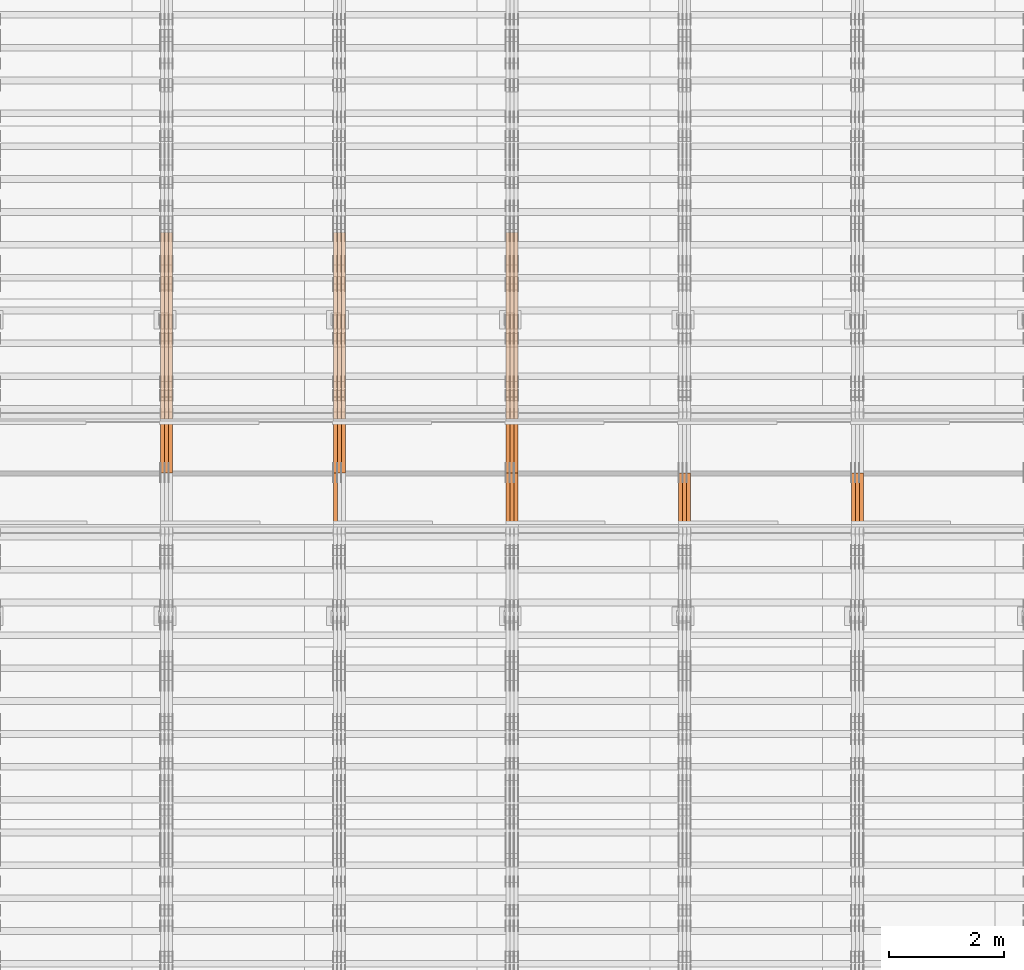
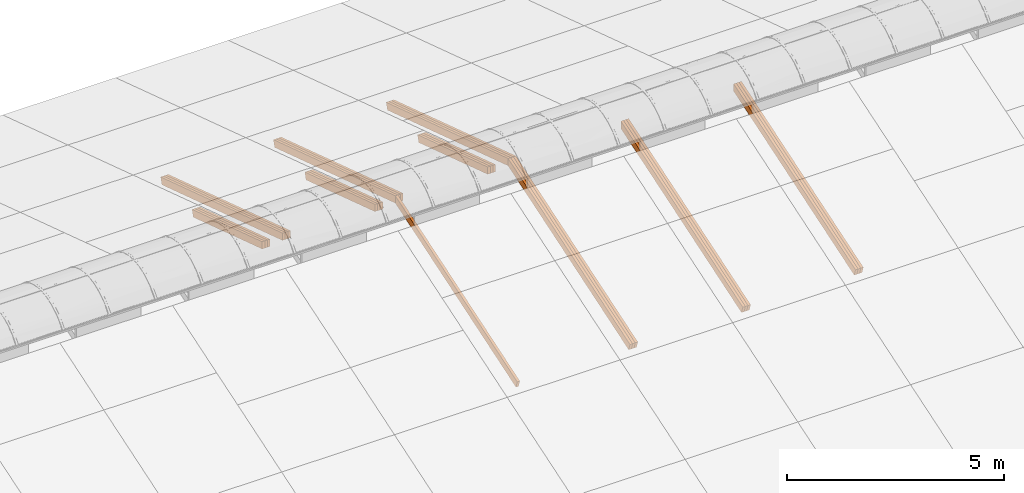
# One storey, part 18 of 385: 28 proxies.
"""IFC2X3 building model written with IfcOpenShell, lengths in millimetres."""

import ifcopenshell
import ifcopenshell.guid

model = None  # the IFC model being written
_history = None  # IfcOwnerHistory: only IFC2X3 demands one
_inside = {}  # id of a spatial element -> (the spatial element, [elements in it])
_under = {}  # id of a project, library or spatial element -> (it, [spatial elements below it])
_declared = {}  # id of a project -> (the project, [libraries it declares])
_typed = {}  # id of a type object -> (the type object, [elements of that type])
_made_of = {}  # id of a material, layer set ... -> (it, [elements and type objects made of it])


def new_model(schema):
    """Start an empty IFC model of exactly this schema.

    Asked for "IFC4X3", IfcOpenShell would pick the latest addendum, in which some entities
    have other attributes; the version numbers below select the first issue.
    IFC2X3 requires an IfcOwnerHistory on every rooted entity: one is made here for all.
    """
    global model, _history
    if schema == "IFC4X3":
        model = ifcopenshell.file(schema_version=(4, 3, 0, 0))
    else:
        model = ifcopenshell.file(schema=schema)
    _inside.clear()
    _under.clear()
    _declared.clear()
    _typed.clear()
    _made_of.clear()
    _history = None
    if model.schema == "IFC2X3":
        org = make("IfcOrganization", Name="unknown")
        user = make(
            "IfcPersonAndOrganization",
            ThePerson=make("IfcPerson", FamilyName="unknown"),
            TheOrganization=org,
        )
        app = make(
            "IfcApplication",
            ApplicationDeveloper=org,
            Version="unknown",
            ApplicationFullName="unknown",
            ApplicationIdentifier="unknown",
        )
        _history = make(
            "IfcOwnerHistory",
            OwningUser=user,
            OwningApplication=app,
            ChangeAction="ADDED",
            CreationDate=0,
        )
    return model


def make(cls, **values):
    """One entity of the class cls with the attributes given. An attribute that is None is left unset."""
    return model.create_entity(
        cls, **{name: value for name, value in values.items() if value is not None}
    )


def entity(cls, *values):
    """Any entity or typed value of the class cls, its attributes in the order of the schema. None: left unset."""
    e = model.create_entity(cls)
    for i, value in enumerate(values):
        if value is not None:
            e[i] = value
    return e


def rooted(cls, **values):
    """An entity with a GlobalId (a new one), such as an element, a storey or a relation."""
    return make(cls, GlobalId=ifcopenshell.guid.new(), OwnerHistory=_history, **values)


def si_unit(unit_type, name, prefix=None):
    """IfcSIUnit, for example si_unit("LENGTHUNIT", "METRE", prefix="MILLI")."""
    return make("IfcSIUnit", UnitType=unit_type, Prefix=prefix, Name=name)


def converted_unit(unit_type, name, factor, base, dimensions=None, offset=None):
    """IfcConversionBasedUnit, such as the inch: factor (a typed value) times the base unit."""
    return make(
        "IfcConversionBasedUnit"
        if offset is None
        else "IfcConversionBasedUnitWithOffset",
        ConversionOffset=offset,
        Dimensions=None
        if dimensions is None
        else entity("IfcDimensionalExponents", *dimensions),
        UnitType=unit_type,
        Name=name,
        ConversionFactor=make(
            "IfcMeasureWithUnit", ValueComponent=factor, UnitComponent=base
        ),
    )


def derived_unit(unit_type, elements):
    """IfcDerivedUnit: a product of units, each with its exponent."""
    return make(
        "IfcDerivedUnit",
        Elements=[
            make("IfcDerivedUnitElement", Unit=unit, Exponent=power)
            for unit, power in elements
        ],
        UnitType=unit_type,
    )


def assignment(units):
    """IfcUnitAssignment: the units of a project."""
    return None if units is None else make("IfcUnitAssignment", Units=units)


def point(xyz):
    """IfcCartesianPoint."""
    return None if xyz is None else make("IfcCartesianPoint", Coordinates=xyz)


def direction(xyz):
    """IfcDirection."""
    return None if xyz is None else make("IfcDirection", DirectionRatios=xyz)


def frame(location, z_axis=None, x_axis=None):
    """IfcAxis2Placement3D, a coordinate frame: its origin and axes. An axis left out is left unset."""
    return make(
        "IfcAxis2Placement3D",
        Location=point(location),
        Axis=direction(z_axis),
        RefDirection=direction(x_axis),
    )


def origin():
    """The frame at (0, 0, 0) with its axes left unset."""
    return frame((0.0, 0.0, 0.0))


def place(relative_to, where):
    """IfcLocalPlacement: puts the frame where relative to a parent placement (None: the world)."""
    return make(
        "IfcLocalPlacement", PlacementRelTo=relative_to, RelativePlacement=where
    )


def context(
    kind, dimensions, precision=None, world=None, true_north=None, identifier=None
):
    """IfcGeometricRepresentationContext, for example the 3D "Model" context."""
    return make(
        "IfcGeometricRepresentationContext",
        ContextIdentifier=identifier,
        ContextType=kind,
        CoordinateSpaceDimension=dimensions,
        Precision=precision,
        WorldCoordinateSystem=world,
        TrueNorth=true_north,
    )


def subcontext(parent, identifier, kind, view, scale=None):
    """IfcGeometricRepresentationSubContext, for example "Body" below "Model"."""
    return make(
        "IfcGeometricRepresentationSubContext",
        ContextIdentifier=identifier,
        ContextType=kind,
        ParentContext=parent,
        TargetScale=scale,
        TargetView=view,
    )


def project(units=None, contexts=None):
    """IfcProject with its units and contexts."""
    return rooted(
        "IfcProject",
        Name="project",
        RepresentationContexts=contexts,
        UnitsInContext=assignment(units),
    )


def spatial(cls, under=None, at=None, **own):
    """A site, building, storey or space (cls), placed at a placement, below another one or the project."""
    s = rooted(cls, ObjectPlacement=at, **own)
    if under is not None:
        _under.setdefault(under.id(), (under, []))[1].append(s)
    return s


def polyline(points):
    """IfcPolyline through the points."""
    return make("IfcPolyline", Points=[point(p) for p in points])


def outline(outer, holes=None, kind="AREA"):
    """IfcArbitraryClosedProfileDef: a profile drawn as a closed curve; with holes, ...WithVoids."""
    if holes is None:
        return make("IfcArbitraryClosedProfileDef", ProfileType=kind, OuterCurve=outer)
    return make(
        "IfcArbitraryProfileDefWithVoids",
        ProfileType=kind,
        OuterCurve=outer,
        InnerCurves=holes,
    )


def extrude(swept, where, along, depth):
    """IfcExtrudedAreaSolid: the profile swept, set in the frame where, extruded along a direction by depth."""
    return make(
        "IfcExtrudedAreaSolid",
        SweptArea=swept,
        Position=where,
        ExtrudedDirection=direction(along),
        Depth=depth,
    )


def shape(context_of_items, identifier, shape_type, items):
    """IfcShapeRepresentation: the items that make up one representation, for example the "Body"."""
    return make(
        "IfcShapeRepresentation",
        ContextOfItems=context_of_items,
        RepresentationIdentifier=identifier,
        RepresentationType=shape_type,
        Items=items,
    )


def source(mapping_origin, context_of_items, identifier, shape_type, items):
    """IfcRepresentationMap: a shape defined once, which mapped items show again and again."""
    return make(
        "IfcRepresentationMap",
        MappingOrigin=mapping_origin,
        MappedRepresentation=shape(context_of_items, identifier, shape_type, items),
    )


def transform(
    local_origin,
    x_axis=None,
    y_axis=None,
    z_axis=None,
    scale=None,
    scale2=None,
    scale3=None,
    uniform=True,
):
    """IfcCartesianTransformationOperator3D, or its non-uniform kind. x_axis, y_axis, z_axis: its Axis1, 2, 3."""
    if uniform:
        return make(
            "IfcCartesianTransformationOperator3D",
            Axis1=direction(x_axis),
            Axis2=direction(y_axis),
            LocalOrigin=point(local_origin),
            Scale=scale,
            Axis3=direction(z_axis),
        )
    return make(
        "IfcCartesianTransformationOperator3DnonUniform",
        Axis1=direction(x_axis),
        Axis2=direction(y_axis),
        LocalOrigin=point(local_origin),
        Scale=scale,
        Axis3=direction(z_axis),
        Scale2=scale2,
        Scale3=scale3,
    )


def mapped(mapping_source, mapping_target):
    """IfcMappedItem: shows the shape of a source again, moved by a transform."""
    return make(
        "IfcMappedItem", MappingSource=mapping_source, MappingTarget=mapping_target
    )


def material(Name=None, Category=None):
    """IfcMaterial."""
    return make("IfcMaterial", Name=Name, Category=Category)


def made_of(thing, what):
    """Note that an element or type object is made of a material, layer set ...; save() writes the relation."""
    if what is not None:
        _made_of.setdefault(what.id(), (what, []))[1].append(thing)
    return thing


def type_object(cls, material=None, **own):
    """A type object (cls), such as IfcWallType, which elements share."""
    return made_of(rooted(cls, **own), material)


def type_shapes(of_type, sources):
    """Give a type object the sources (RepresentationMaps) that its elements show as mapped items."""
    of_type.RepresentationMaps = sources


def element(
    cls,
    number,
    at=None,
    inside=None,
    cuts=None,
    type_object=None,
    material=None,
    context=None,
    identifier="Body",
    shape_type=None,
    held_by="IfcProductDefinitionShape",
    body=None,
    shapes=None,
    **own,
):
    """One element of the class cls, such as IfcWall. Its Tag is "e" and its number.

    at: its placement. inside: the storey or other place that contains it. cuts: it is an
    opening in that element (IfcRelVoidsElement). A single representation is given by context,
    identifier, shape_type and body (its items); several are given by shapes. held_by: the class
    of the entity that holds the representations. save() writes the other relations.
    """
    e = rooted(cls, Tag="e%d" % number, ObjectPlacement=at, **own)
    if body is not None:
        shapes = [shape(context, identifier, shape_type, body)]
    if shapes is not None:
        e.Representation = make(held_by, Representations=shapes)
    if inside is not None:
        _inside.setdefault(inside.id(), (inside, []))[1].append(e)
    if cuts is not None:
        rooted(
            "IfcRelVoidsElement", RelatingBuildingElement=cuts, RelatedOpeningElement=e
        )
    if type_object is not None:
        _typed.setdefault(type_object.id(), (type_object, []))[1].append(e)
    return made_of(e, material)


def aggregate(whole, parts):
    """IfcRelAggregates: a whole, such as a stair, and the parts it consists of."""
    return rooted("IfcRelAggregates", RelatingObject=whole, RelatedObjects=parts)


def save(model, path):
    """Write the relations noted so far, then the file.

    IfcRelAggregates (storeys below a building ...), IfcRelContainedInSpatialStructure (elements
    in a storey), IfcRelDefinesByType, IfcRelAssociatesMaterial and IfcRelDeclares: one each for
    every whole, place, type object, material and project.
    """
    for whole, parts in _under.values():
        aggregate(whole, parts)
    for where, things in _inside.values():
        rooted(
            "IfcRelContainedInSpatialStructure",
            RelatedElements=things,
            RelatingStructure=where,
        )
    for kind, things in _typed.values():
        rooted("IfcRelDefinesByType", RelatedObjects=things, RelatingType=kind)
    for what, things in _made_of.values():
        rooted("IfcRelAssociatesMaterial", RelatedObjects=things, RelatingMaterial=what)
    for by, libraries in _declared.values():
        rooted("IfcRelDeclares", RelatingContext=by, RelatedDefinitions=libraries)
    model.write(path)


model = new_model("IFC2X3")

# Units and contexts
model_context = context("Model", 3, precision=0.01, world=origin(), true_north=direction((6.12303176911189e-17, 1.0)))
body_context = subcontext(model_context, "Body", "Model", "MODEL_VIEW")
ifc_project = project(units=[si_unit("LENGTHUNIT", "METRE", prefix="MILLI"), si_unit("AREAUNIT", "SQUARE_METRE"), si_unit("VOLUMEUNIT", "CUBIC_METRE"), converted_unit("PLANEANGLEUNIT", "DEGREE", entity("IfcRatioMeasure", 0.0174532925199433), si_unit("PLANEANGLEUNIT", "RADIAN"), dimensions=[0, 0, 0, 0, 0, 0, 0]), si_unit("MASSUNIT", "GRAM", prefix="KILO"), derived_unit("MASSDENSITYUNIT", [(si_unit("MASSUNIT", "GRAM", prefix="KILO"), 1), (si_unit("LENGTHUNIT", "METRE"), -3)]), si_unit("TIMEUNIT", "SECOND"), si_unit("FREQUENCYUNIT", "HERTZ"), si_unit("THERMODYNAMICTEMPERATUREUNIT", "DEGREE_CELSIUS"), derived_unit("THERMALTRANSMITTANCEUNIT", [(si_unit("MASSUNIT", "GRAM", prefix="KILO"), 1), (si_unit("THERMODYNAMICTEMPERATUREUNIT", "KELVIN"), -1), (si_unit("TIMEUNIT", "SECOND"), -3)]), derived_unit("VOLUMETRICFLOWRATEUNIT", [(si_unit("LENGTHUNIT", "METRE"), 3), (si_unit("TIMEUNIT", "SECOND"), -1)]), si_unit("ELECTRICCURRENTUNIT", "AMPERE"), si_unit("ELECTRICVOLTAGEUNIT", "VOLT"), si_unit("POWERUNIT", "WATT"), si_unit("FORCEUNIT", "NEWTON", prefix="KILO"), si_unit("ILLUMINANCEUNIT", "LUX"), si_unit("LUMINOUSFLUXUNIT", "LUMEN"), si_unit("LUMINOUSINTENSITYUNIT", "CANDELA"), derived_unit("USERDEFINED", [(si_unit("MASSUNIT", "GRAM", prefix="KILO"), -1), (si_unit("LENGTHUNIT", "METRE"), -2), (si_unit("TIMEUNIT", "SECOND"), 3), (si_unit("LUMINOUSFLUXUNIT", "LUMEN"), 1)]), derived_unit("LINEARVELOCITYUNIT", [(si_unit("LENGTHUNIT", "METRE"), 1), (si_unit("TIMEUNIT", "SECOND"), -1)]), si_unit("PRESSUREUNIT", "PASCAL"), derived_unit("USERDEFINED", [(si_unit("LENGTHUNIT", "METRE"), -2), (si_unit("MASSUNIT", "GRAM", prefix="KILO"), 1), (si_unit("TIMEUNIT", "SECOND"), -2)])], contexts=[model_context])

# Site, building, storey
site_placement = place(None, origin())
site = spatial("IfcSite", under=ifc_project, at=site_placement, CompositionType="ELEMENT")
building_placement = place(site_placement, origin())
building = spatial("IfcBuilding", under=site, at=building_placement, CompositionType="ELEMENT")
storey_placement = place(building_placement, origin())
storey = spatial("IfcBuildingStorey", under=building, at=storey_placement, Name="Default", CompositionType="ELEMENT", Elevation=0.0)

# Proxies
ifc_material_1 = material(Name="IfcSurfaceStyle #351825")
building_element_proxy_type_1 = type_object("IfcBuildingElementProxyType", Name="T1-T1 351823", PredefinedType="NOTDEFINED", material=ifc_material_1)
shared_shape_1 = source(origin(), body_context, "Body", "SweptSolid", [
    extrude(outline(polyline([(-2938.84391703088, -97.499801613968), (2970.52383457984, -97.499801613968), (2907.16448685427, 97.499801613968), (-2938.84440440323, 97.499801613968), (-2938.84391703088, -97.499801613968)])), frame((2970.52383457984, 97.5000757893295, 0.0), z_axis=(0.0, 0.0, 1.0), x_axis=(-1.0, 0.0, 0.0)), (0.0, 0.0, 1.0), 69.9999999999996),
])
type_shapes(building_element_proxy_type_1, [shared_shape_1])
proxy_1_placement = place(building_placement, frame((30385.0, 14780.2584052475, 4242.0978974122), z_axis=(-1.0, 0.0, 0.0), x_axis=(0.0, -0.951056516295154, -0.309016994374948)))
element("IfcBuildingElementProxy", 1, at=proxy_1_placement, inside=storey, type_object=building_element_proxy_type_1, material=ifc_material_1, Name="T1-T1", context=body_context, shape_type="MappedRepresentation", body=[
    mapped(shared_shape_1, transform((0.0, 0.0, 0.0), scale=1.0)),
])
ifc_material_2 = material(Name="IfcSurfaceStyle #351768")
building_element_proxy_type_2 = type_object("IfcBuildingElementProxyType", Name="T1-T1 351766", PredefinedType="NOTDEFINED", material=ifc_material_2)
shared_shape_2 = source(origin(), body_context, "Body", "SweptSolid", [
    extrude(outline(polyline([(-2938.84391703088, -97.499801613968), (2970.52383457984, -97.499801613968), (2907.16448685427, 97.499801613968), (-2938.84440440323, 97.499801613968), (-2938.84391703088, -97.499801613968)])), frame((2970.52383457984, 97.5000757893295, 0.0), z_axis=(0.0, 0.0, 1.0), x_axis=(-1.0, 0.0, 0.0)), (0.0, 0.0, 1.0), 69.9999999999996),
])
type_shapes(building_element_proxy_type_2, [shared_shape_2])
proxy_2_placement = place(building_placement, frame((30315.0, 14780.2584052475, 4242.0978974122), z_axis=(-1.0, 0.0, 0.0), x_axis=(0.0, -0.951056516295154, -0.309016994374948)))
element("IfcBuildingElementProxy", 2, at=proxy_2_placement, inside=storey, type_object=building_element_proxy_type_2, material=ifc_material_2, Name="T1-T1", context=body_context, shape_type="MappedRepresentation", body=[
    mapped(shared_shape_2, transform((0.0, 0.0, 0.0), scale=1.0)),
])
ifc_material_3 = material(Name="IfcSurfaceStyle #351711")
building_element_proxy_type_3 = type_object("IfcBuildingElementProxyType", Name="T1-T1 351709", PredefinedType="NOTDEFINED", material=ifc_material_3)
shared_shape_3 = source(origin(), body_context, "Body", "SweptSolid", [
    extrude(outline(polyline([(-2938.84391703088, -97.499801613968), (2970.52383457984, -97.499801613968), (2907.16448685427, 97.499801613968), (-2938.84440440323, 97.499801613968), (-2938.84391703088, -97.499801613968)])), frame((2970.52383457984, 97.5000757893295, 0.0), z_axis=(0.0, 0.0, 1.0), x_axis=(-1.0, 0.0, 0.0)), (0.0, 0.0, 1.0), 69.9999999999996),
])
type_shapes(building_element_proxy_type_3, [shared_shape_3])
proxy_3_placement = place(building_placement, frame((30245.0, 14780.2584052475, 4242.0978974122), z_axis=(-1.0, 0.0, 0.0), x_axis=(0.0, -0.951056516295154, -0.309016994374948)))
element("IfcBuildingElementProxy", 3, at=proxy_3_placement, inside=storey, type_object=building_element_proxy_type_3, material=ifc_material_3, Name="T1-T1", context=body_context, shape_type="MappedRepresentation", body=[
    mapped(shared_shape_3, transform((0.0, 0.0, 0.0), scale=1.0)),
])
ifc_material_4 = material(Name="IfcSurfaceStyle #317393")
building_element_proxy_type_4 = type_object("IfcBuildingElementProxyType", Name="T1-T1 317391", PredefinedType="NOTDEFINED", material=ifc_material_4)
shared_shape_4 = source(origin(), body_context, "Body", "SweptSolid", [
    extrude(outline(polyline([(-2938.84391703088, -97.499801613968), (2970.52383457984, -97.499801613968), (2907.16448685427, 97.499801613968), (-2938.84440440323, 97.499801613968), (-2938.84391703088, -97.499801613968)])), frame((2970.52383457984, 97.5000757893295, 0.0), z_axis=(0.0, 0.0, 1.0), x_axis=(-1.0, 0.0, 0.0)), (0.0, 0.0, 1.0), 69.9999999999996),
])
type_shapes(building_element_proxy_type_4, [shared_shape_4])
proxy_4_placement = place(building_placement, frame((27385.0, 14780.2584052475, 4242.0978974122), z_axis=(-1.0, 0.0, 0.0), x_axis=(0.0, -0.951056516295154, -0.309016994374948)))
element("IfcBuildingElementProxy", 4, at=proxy_4_placement, inside=storey, type_object=building_element_proxy_type_4, material=ifc_material_4, Name="T1-T1", context=body_context, shape_type="MappedRepresentation", body=[
    mapped(shared_shape_4, transform((0.0, 0.0, 0.0), scale=1.0)),
])
ifc_material_5 = material(Name="IfcSurfaceStyle #317336")
building_element_proxy_type_5 = type_object("IfcBuildingElementProxyType", Name="T1-T1 317334", PredefinedType="NOTDEFINED", material=ifc_material_5)
shared_shape_5 = source(origin(), body_context, "Body", "SweptSolid", [
    extrude(outline(polyline([(-2938.84391703088, -97.499801613968), (2970.52383457984, -97.499801613968), (2907.16448685427, 97.499801613968), (-2938.84440440323, 97.499801613968), (-2938.84391703088, -97.499801613968)])), frame((2970.52383457984, 97.5000757893295, 0.0), z_axis=(0.0, 0.0, 1.0), x_axis=(-1.0, 0.0, 0.0)), (0.0, 0.0, 1.0), 69.9999999999996),
])
type_shapes(building_element_proxy_type_5, [shared_shape_5])
proxy_5_placement = place(building_placement, frame((27315.0, 14780.2584052475, 4242.0978974122), z_axis=(-1.0, 0.0, 0.0), x_axis=(0.0, -0.951056516295154, -0.309016994374948)))
element("IfcBuildingElementProxy", 5, at=proxy_5_placement, inside=storey, type_object=building_element_proxy_type_5, material=ifc_material_5, Name="T1-T1", context=body_context, shape_type="MappedRepresentation", body=[
    mapped(shared_shape_5, transform((0.0, 0.0, 0.0), scale=1.0)),
])
ifc_material_6 = material(Name="IfcSurfaceStyle #317279")
building_element_proxy_type_6 = type_object("IfcBuildingElementProxyType", Name="T1-T1 317277", PredefinedType="NOTDEFINED", material=ifc_material_6)
shared_shape_6 = source(origin(), body_context, "Body", "SweptSolid", [
    extrude(outline(polyline([(-2938.84391703088, -97.499801613968), (2970.52383457984, -97.499801613968), (2907.16448685427, 97.499801613968), (-2938.84440440323, 97.499801613968), (-2938.84391703088, -97.499801613968)])), frame((2970.52383457984, 97.5000757893295, 0.0), z_axis=(0.0, 0.0, 1.0), x_axis=(-1.0, 0.0, 0.0)), (0.0, 0.0, 1.0), 69.9999999999996),
])
type_shapes(building_element_proxy_type_6, [shared_shape_6])
proxy_6_placement = place(building_placement, frame((27245.0, 14780.2584052475, 4242.0978974122), z_axis=(-1.0, 0.0, 0.0), x_axis=(0.0, -0.951056516295154, -0.309016994374948)))
element("IfcBuildingElementProxy", 6, at=proxy_6_placement, inside=storey, type_object=building_element_proxy_type_6, material=ifc_material_6, Name="T1-T1", context=body_context, shape_type="MappedRepresentation", body=[
    mapped(shared_shape_6, transform((0.0, 0.0, 0.0), scale=1.0)),
])
ifc_material_7 = material(Name="IfcSurfaceStyle #283816")
building_element_proxy_type_7 = type_object("IfcBuildingElementProxyType", Name="T1-T1 283814", PredefinedType="NOTDEFINED", material=ifc_material_7)
shared_shape_7 = source(origin(), body_context, "Body", "SweptSolid", [
    extrude(outline(polyline([(-2970.52406677137, -97.5001477982598), (2938.84461360547, -97.5001477982598), (2938.8441722117, 97.5001477982599), (-2907.1647190458, 97.5001477982598), (-2970.52406677137, -97.5001477982598)])), frame((2938.84461360547, 97.5001477982598, 0.0), z_axis=(0.0, 0.0, 1.0), x_axis=(-1.0, 0.0, 0.0)), (0.0, 0.0, 1.0), 69.9999999999996),
])
type_shapes(building_element_proxy_type_7, [shared_shape_7])
proxy_7_placement = place(building_placement, frame((24385.0, 20279.8851854154, 2416.0025491487), z_axis=(-1.0, 0.0, 0.0), x_axis=(0.0, -0.951056516295154, 0.309016994374948)))
element("IfcBuildingElementProxy", 7, at=proxy_7_placement, inside=storey, type_object=building_element_proxy_type_7, material=ifc_material_7, Name="T1-T1", context=body_context, shape_type="MappedRepresentation", body=[
    mapped(shared_shape_7, transform((0.0, 0.0, 0.0), scale=1.0)),
])
ifc_material_8 = material(Name="IfcSurfaceStyle #283759")
building_element_proxy_type_8 = type_object("IfcBuildingElementProxyType", Name="T1-T1 283757", PredefinedType="NOTDEFINED", material=ifc_material_8)
shared_shape_8 = source(origin(), body_context, "Body", "SweptSolid", [
    extrude(outline(polyline([(-2970.52406677137, -97.5001477982598), (2938.84461360547, -97.5001477982598), (2938.8441722117, 97.5001477982599), (-2907.1647190458, 97.5001477982598), (-2970.52406677137, -97.5001477982598)])), frame((2938.84461360547, 97.5001477982598, 0.0), z_axis=(0.0, 0.0, 1.0), x_axis=(-1.0, 0.0, 0.0)), (0.0, 0.0, 1.0), 69.9999999999996),
])
type_shapes(building_element_proxy_type_8, [shared_shape_8])
proxy_8_placement = place(building_placement, frame((24315.0, 20279.8851854154, 2416.0025491487), z_axis=(-1.0, 0.0, 0.0), x_axis=(0.0, -0.951056516295154, 0.309016994374948)))
element("IfcBuildingElementProxy", 8, at=proxy_8_placement, inside=storey, type_object=building_element_proxy_type_8, material=ifc_material_8, Name="T1-T1", context=body_context, shape_type="MappedRepresentation", body=[
    mapped(shared_shape_8, transform((0.0, 0.0, 0.0), scale=1.0)),
])
ifc_material_9 = material(Name="IfcSurfaceStyle #283702")
building_element_proxy_type_9 = type_object("IfcBuildingElementProxyType", Name="T1-T1 283700", PredefinedType="NOTDEFINED", material=ifc_material_9)
shared_shape_9 = source(origin(), body_context, "Body", "SweptSolid", [
    extrude(outline(polyline([(-2970.52406677137, -97.5001477982598), (2938.84461360547, -97.5001477982598), (2938.8441722117, 97.5001477982599), (-2907.1647190458, 97.5001477982598), (-2970.52406677137, -97.5001477982598)])), frame((2938.84461360547, 97.5001477982598, 0.0), z_axis=(0.0, 0.0, 1.0), x_axis=(-1.0, 0.0, 0.0)), (0.0, 0.0, 1.0), 69.9999999999996),
])
type_shapes(building_element_proxy_type_9, [shared_shape_9])
proxy_9_placement = place(building_placement, frame((24245.0, 20279.8851854154, 2416.0025491487), z_axis=(-1.0, 0.0, 0.0), x_axis=(0.0, -0.951056516295154, 0.309016994374948)))
element("IfcBuildingElementProxy", 9, at=proxy_9_placement, inside=storey, type_object=building_element_proxy_type_9, material=ifc_material_9, Name="T1-T1", context=body_context, shape_type="MappedRepresentation", body=[
    mapped(shared_shape_9, transform((0.0, 0.0, 0.0), scale=1.0)),
])
ifc_material_10 = material(Name="IfcSurfaceStyle #282961")
building_element_proxy_type_10 = type_object("IfcBuildingElementProxyType", Name="T1-T1 282959", PredefinedType="NOTDEFINED", material=ifc_material_10)
shared_shape_10 = source(origin(), body_context, "Body", "SweptSolid", [
    extrude(outline(polyline([(-2938.84391703088, -97.499801613968), (2970.52383457984, -97.499801613968), (2907.16448685427, 97.499801613968), (-2938.84440440323, 97.499801613968), (-2938.84391703088, -97.499801613968)])), frame((2970.52383457984, 97.5000757893295, 0.0), z_axis=(0.0, 0.0, 1.0), x_axis=(-1.0, 0.0, 0.0)), (0.0, 0.0, 1.0), 69.9999999999996),
])
type_shapes(building_element_proxy_type_10, [shared_shape_10])
proxy_10_placement = place(building_placement, frame((24385.0, 14780.2584052475, 4242.0978974122), z_axis=(-1.0, 0.0, 0.0), x_axis=(0.0, -0.951056516295154, -0.309016994374948)))
element("IfcBuildingElementProxy", 10, at=proxy_10_placement, inside=storey, type_object=building_element_proxy_type_10, material=ifc_material_10, Name="T1-T1", context=body_context, shape_type="MappedRepresentation", body=[
    mapped(shared_shape_10, transform((0.0, 0.0, 0.0), scale=1.0)),
])
ifc_material_11 = material(Name="IfcSurfaceStyle #282904")
building_element_proxy_type_11 = type_object("IfcBuildingElementProxyType", Name="T1-T1 282902", PredefinedType="NOTDEFINED", material=ifc_material_11)
shared_shape_11 = source(origin(), body_context, "Body", "SweptSolid", [
    extrude(outline(polyline([(-2938.84391703088, -97.499801613968), (2970.52383457984, -97.499801613968), (2907.16448685427, 97.499801613968), (-2938.84440440323, 97.499801613968), (-2938.84391703088, -97.499801613968)])), frame((2970.52383457984, 97.5000757893295, 0.0), z_axis=(0.0, 0.0, 1.0), x_axis=(-1.0, 0.0, 0.0)), (0.0, 0.0, 1.0), 69.9999999999996),
])
type_shapes(building_element_proxy_type_11, [shared_shape_11])
proxy_11_placement = place(building_placement, frame((24315.0, 14780.2584052475, 4242.0978974122), z_axis=(-1.0, 0.0, 0.0), x_axis=(0.0, -0.951056516295154, -0.309016994374948)))
element("IfcBuildingElementProxy", 11, at=proxy_11_placement, inside=storey, type_object=building_element_proxy_type_11, material=ifc_material_11, Name="T1-T1", context=body_context, shape_type="MappedRepresentation", body=[
    mapped(shared_shape_11, transform((0.0, 0.0, 0.0), scale=1.0)),
])
ifc_material_12 = material(Name="IfcSurfaceStyle #282847")
building_element_proxy_type_12 = type_object("IfcBuildingElementProxyType", Name="T1-T1 282845", PredefinedType="NOTDEFINED", material=ifc_material_12)
shared_shape_12 = source(origin(), body_context, "Body", "SweptSolid", [
    extrude(outline(polyline([(-2938.84391703088, -97.499801613968), (2970.52383457984, -97.499801613968), (2907.16448685427, 97.499801613968), (-2938.84440440323, 97.499801613968), (-2938.84391703088, -97.499801613968)])), frame((2970.52383457984, 97.5000757893295, 0.0), z_axis=(0.0, 0.0, 1.0), x_axis=(-1.0, 0.0, 0.0)), (0.0, 0.0, 1.0), 69.9999999999996),
])
type_shapes(building_element_proxy_type_12, [shared_shape_12])
proxy_12_placement = place(building_placement, frame((24245.0, 14780.2584052475, 4242.0978974122), z_axis=(-1.0, 0.0, 0.0), x_axis=(0.0, -0.951056516295154, -0.309016994374948)))
element("IfcBuildingElementProxy", 12, at=proxy_12_placement, inside=storey, type_object=building_element_proxy_type_12, material=ifc_material_12, Name="T1-T1", context=body_context, shape_type="MappedRepresentation", body=[
    mapped(shared_shape_12, transform((0.0, 0.0, 0.0), scale=1.0)),
])
ifc_material_13 = material(Name="IfcSurfaceStyle #282421")
building_element_proxy_type_13 = type_object("IfcBuildingElementProxyType", Name="T1-B3 282419", PredefinedType="NOTDEFINED", material=ifc_material_13)
shared_shape_13 = source(origin(), body_context, "Body", "SweptSolid", [
    extrude(outline(polyline([(-1715.8757175801, -97.4999653079672), (1684.19580003112, -97.4999653079672), (1684.19628740349, 97.4999653079672), (-1652.51636985451, 97.4999653079672), (-1715.8757175801, -97.4999653079672)])), frame((1684.19628740349, 97.5000561131842, 0.0), z_axis=(0.0, 0.0, 1.0), x_axis=(-1.0, 0.0, 0.0)), (0.0, 0.0, 1.0), 69.9999999999998),
])
type_shapes(building_element_proxy_type_13, [shared_shape_13])
proxy_13_placement = place(building_placement, frame((24385.0, 18833.4023156896, 2380.55582184223), z_axis=(-1.0, 0.0, 0.0), x_axis=(0.0, -0.951056516295124, 0.309016994375039)))
element("IfcBuildingElementProxy", 13, at=proxy_13_placement, inside=storey, type_object=building_element_proxy_type_13, material=ifc_material_13, Name="T1-B3", context=body_context, shape_type="MappedRepresentation", body=[
    mapped(shared_shape_13, transform((0.0, 0.0, 0.0), scale=1.0)),
])
ifc_material_14 = material(Name="IfcSurfaceStyle #282364")
building_element_proxy_type_14 = type_object("IfcBuildingElementProxyType", Name="T1-B3 282362", PredefinedType="NOTDEFINED", material=ifc_material_14)
shared_shape_14 = source(origin(), body_context, "Body", "SweptSolid", [
    extrude(outline(polyline([(-1715.8757175801, -97.4999653079672), (1684.19580003112, -97.4999653079672), (1684.19628740349, 97.4999653079672), (-1652.51636985451, 97.4999653079672), (-1715.8757175801, -97.4999653079672)])), frame((1684.19628740349, 97.5000561131842, 0.0), z_axis=(0.0, 0.0, 1.0), x_axis=(-1.0, 0.0, 0.0)), (0.0, 0.0, 1.0), 69.9999999999998),
])
type_shapes(building_element_proxy_type_14, [shared_shape_14])
proxy_14_placement = place(building_placement, frame((24315.0, 18833.4023156896, 2380.55582184223), z_axis=(-1.0, 0.0, 0.0), x_axis=(0.0, -0.951056516295124, 0.309016994375039)))
element("IfcBuildingElementProxy", 14, at=proxy_14_placement, inside=storey, type_object=building_element_proxy_type_14, material=ifc_material_14, Name="T1-B3", context=body_context, shape_type="MappedRepresentation", body=[
    mapped(shared_shape_14, transform((0.0, 0.0, 0.0), scale=1.0)),
])
ifc_material_15 = material(Name="IfcSurfaceStyle #282307")
building_element_proxy_type_15 = type_object("IfcBuildingElementProxyType", Name="T1-B3 282305", PredefinedType="NOTDEFINED", material=ifc_material_15)
shared_shape_15 = source(origin(), body_context, "Body", "SweptSolid", [
    extrude(outline(polyline([(-1715.8757175801, -97.4999653079672), (1684.19580003112, -97.4999653079672), (1684.19628740349, 97.4999653079672), (-1652.51636985451, 97.4999653079672), (-1715.8757175801, -97.4999653079672)])), frame((1684.19628740349, 97.5000561131842, 0.0), z_axis=(0.0, 0.0, 1.0), x_axis=(-1.0, 0.0, 0.0)), (0.0, 0.0, 1.0), 69.9999999999998),
])
type_shapes(building_element_proxy_type_15, [shared_shape_15])
proxy_15_placement = place(building_placement, frame((24245.0, 18833.4023156896, 2380.55582184223), z_axis=(-1.0, 0.0, 0.0), x_axis=(0.0, -0.951056516295124, 0.309016994375039)))
element("IfcBuildingElementProxy", 15, at=proxy_15_placement, inside=storey, type_object=building_element_proxy_type_15, material=ifc_material_15, Name="T1-B3", context=body_context, shape_type="MappedRepresentation", body=[
    mapped(shared_shape_15, transform((0.0, 0.0, 0.0), scale=1.0)),
])
ifc_material_16 = material(Name="IfcSurfaceStyle #249384")
building_element_proxy_type_16 = type_object("IfcBuildingElementProxyType", Name="T1-T1 249382", PredefinedType="NOTDEFINED", material=ifc_material_16)
shared_shape_16 = source(origin(), body_context, "Body", "SweptSolid", [
    extrude(outline(polyline([(-2970.52406677137, -97.5001477982598), (2938.84461360547, -97.5001477982598), (2938.8441722117, 97.5001477982599), (-2907.1647190458, 97.5001477982598), (-2970.52406677137, -97.5001477982598)])), frame((2938.84461360547, 97.5001477982598, 0.0), z_axis=(0.0, 0.0, 1.0), x_axis=(-1.0, 0.0, 0.0)), (0.0, 0.0, 1.0), 69.9999999999996),
])
type_shapes(building_element_proxy_type_16, [shared_shape_16])
proxy_16_placement = place(building_placement, frame((21385.0, 20279.8851854154, 2416.0025491487), z_axis=(-1.0, 0.0, 0.0), x_axis=(0.0, -0.951056516295154, 0.309016994374948)))
element("IfcBuildingElementProxy", 16, at=proxy_16_placement, inside=storey, type_object=building_element_proxy_type_16, material=ifc_material_16, Name="T1-T1", context=body_context, shape_type="MappedRepresentation", body=[
    mapped(shared_shape_16, transform((0.0, 0.0, 0.0), scale=1.0)),
])
ifc_material_17 = material(Name="IfcSurfaceStyle #249327")
building_element_proxy_type_17 = type_object("IfcBuildingElementProxyType", Name="T1-T1 249325", PredefinedType="NOTDEFINED", material=ifc_material_17)
shared_shape_17 = source(origin(), body_context, "Body", "SweptSolid", [
    extrude(outline(polyline([(-2970.52406677137, -97.5001477982598), (2938.84461360547, -97.5001477982598), (2938.8441722117, 97.5001477982599), (-2907.1647190458, 97.5001477982598), (-2970.52406677137, -97.5001477982598)])), frame((2938.84461360547, 97.5001477982598, 0.0), z_axis=(0.0, 0.0, 1.0), x_axis=(-1.0, 0.0, 0.0)), (0.0, 0.0, 1.0), 69.9999999999996),
])
type_shapes(building_element_proxy_type_17, [shared_shape_17])
proxy_17_placement = place(building_placement, frame((21315.0, 20279.8851854154, 2416.0025491487), z_axis=(-1.0, 0.0, 0.0), x_axis=(0.0, -0.951056516295154, 0.309016994374948)))
element("IfcBuildingElementProxy", 17, at=proxy_17_placement, inside=storey, type_object=building_element_proxy_type_17, material=ifc_material_17, Name="T1-T1", context=body_context, shape_type="MappedRepresentation", body=[
    mapped(shared_shape_17, transform((0.0, 0.0, 0.0), scale=1.0)),
])
ifc_material_18 = material(Name="IfcSurfaceStyle #249270")
building_element_proxy_type_18 = type_object("IfcBuildingElementProxyType", Name="T1-T1 249268", PredefinedType="NOTDEFINED", material=ifc_material_18)
shared_shape_18 = source(origin(), body_context, "Body", "SweptSolid", [
    extrude(outline(polyline([(-2970.52406677137, -97.5001477982598), (2938.84461360547, -97.5001477982598), (2938.8441722117, 97.5001477982599), (-2907.1647190458, 97.5001477982598), (-2970.52406677137, -97.5001477982598)])), frame((2938.84461360547, 97.5001477982598, 0.0), z_axis=(0.0, 0.0, 1.0), x_axis=(-1.0, 0.0, 0.0)), (0.0, 0.0, 1.0), 69.9999999999996),
])
type_shapes(building_element_proxy_type_18, [shared_shape_18])
proxy_18_placement = place(building_placement, frame((21245.0, 20279.8851854154, 2416.0025491487), z_axis=(-1.0, 0.0, 0.0), x_axis=(0.0, -0.951056516295154, 0.309016994374948)))
element("IfcBuildingElementProxy", 18, at=proxy_18_placement, inside=storey, type_object=building_element_proxy_type_18, material=ifc_material_18, Name="T1-T1", context=body_context, shape_type="MappedRepresentation", body=[
    mapped(shared_shape_18, transform((0.0, 0.0, 0.0), scale=1.0)),
])
ifc_material_19 = material(Name="IfcSurfaceStyle #248415")
building_element_proxy_type_19 = type_object("IfcBuildingElementProxyType", Name="T1-T1 248413", PredefinedType="NOTDEFINED", material=ifc_material_19)
shared_shape_19 = source(origin(), body_context, "Body", "SweptSolid", [
    extrude(outline(polyline([(-2938.84391703088, -97.499801613968), (2970.52383457984, -97.499801613968), (2907.16448685427, 97.499801613968), (-2938.84440440323, 97.499801613968), (-2938.84391703088, -97.499801613968)])), frame((2970.52383457984, 97.5000757893295, 0.0), z_axis=(0.0, 0.0, 1.0), x_axis=(-1.0, 0.0, 0.0)), (0.0, 0.0, 1.0), 69.9999999999996),
])
type_shapes(building_element_proxy_type_19, [shared_shape_19])
proxy_19_placement = place(building_placement, frame((21245.0, 14780.2584052475, 4242.0978974122), z_axis=(-1.0, 0.0, 0.0), x_axis=(0.0, -0.951056516295154, -0.309016994374948)))
element("IfcBuildingElementProxy", 19, at=proxy_19_placement, inside=storey, type_object=building_element_proxy_type_19, material=ifc_material_19, Name="T1-T1", context=body_context, shape_type="MappedRepresentation", body=[
    mapped(shared_shape_19, transform((0.0, 0.0, 0.0), scale=1.0)),
])
ifc_material_20 = material(Name="IfcSurfaceStyle #247989")
building_element_proxy_type_20 = type_object("IfcBuildingElementProxyType", Name="T1-B3 247987", PredefinedType="NOTDEFINED", material=ifc_material_20)
shared_shape_20 = source(origin(), body_context, "Body", "SweptSolid", [
    extrude(outline(polyline([(-1715.8757175801, -97.4999653079672), (1684.19580003112, -97.4999653079672), (1684.19628740349, 97.4999653079672), (-1652.51636985451, 97.4999653079672), (-1715.8757175801, -97.4999653079672)])), frame((1684.19628740349, 97.5000561131842, 0.0), z_axis=(0.0, 0.0, 1.0), x_axis=(-1.0, 0.0, 0.0)), (0.0, 0.0, 1.0), 69.9999999999998),
])
type_shapes(building_element_proxy_type_20, [shared_shape_20])
proxy_20_placement = place(building_placement, frame((21385.0, 18833.4023156896, 2380.55582184223), z_axis=(-1.0, 0.0, 0.0), x_axis=(0.0, -0.951056516295124, 0.309016994375039)))
element("IfcBuildingElementProxy", 20, at=proxy_20_placement, inside=storey, type_object=building_element_proxy_type_20, material=ifc_material_20, Name="T1-B3", context=body_context, shape_type="MappedRepresentation", body=[
    mapped(shared_shape_20, transform((0.0, 0.0, 0.0), scale=1.0)),
])
ifc_material_21 = material(Name="IfcSurfaceStyle #247932")
building_element_proxy_type_21 = type_object("IfcBuildingElementProxyType", Name="T1-B3 247930", PredefinedType="NOTDEFINED", material=ifc_material_21)
shared_shape_21 = source(origin(), body_context, "Body", "SweptSolid", [
    extrude(outline(polyline([(-1715.8757175801, -97.4999653079672), (1684.19580003112, -97.4999653079672), (1684.19628740349, 97.4999653079672), (-1652.51636985451, 97.4999653079672), (-1715.8757175801, -97.4999653079672)])), frame((1684.19628740349, 97.5000561131842, 0.0), z_axis=(0.0, 0.0, 1.0), x_axis=(-1.0, 0.0, 0.0)), (0.0, 0.0, 1.0), 69.9999999999998),
])
type_shapes(building_element_proxy_type_21, [shared_shape_21])
proxy_21_placement = place(building_placement, frame((21315.0, 18833.4023156896, 2380.55582184223), z_axis=(-1.0, 0.0, 0.0), x_axis=(0.0, -0.951056516295124, 0.309016994375039)))
element("IfcBuildingElementProxy", 21, at=proxy_21_placement, inside=storey, type_object=building_element_proxy_type_21, material=ifc_material_21, Name="T1-B3", context=body_context, shape_type="MappedRepresentation", body=[
    mapped(shared_shape_21, transform((0.0, 0.0, 0.0), scale=1.0)),
])
ifc_material_22 = material(Name="IfcSurfaceStyle #247875")
building_element_proxy_type_22 = type_object("IfcBuildingElementProxyType", Name="T1-B3 247873", PredefinedType="NOTDEFINED", material=ifc_material_22)
shared_shape_22 = source(origin(), body_context, "Body", "SweptSolid", [
    extrude(outline(polyline([(-1715.8757175801, -97.4999653079672), (1684.19580003112, -97.4999653079672), (1684.19628740349, 97.4999653079672), (-1652.51636985451, 97.4999653079672), (-1715.8757175801, -97.4999653079672)])), frame((1684.19628740349, 97.5000561131842, 0.0), z_axis=(0.0, 0.0, 1.0), x_axis=(-1.0, 0.0, 0.0)), (0.0, 0.0, 1.0), 69.9999999999998),
])
type_shapes(building_element_proxy_type_22, [shared_shape_22])
proxy_22_placement = place(building_placement, frame((21245.0, 18833.4023156896, 2380.55582184223), z_axis=(-1.0, 0.0, 0.0), x_axis=(0.0, -0.951056516295124, 0.309016994375039)))
element("IfcBuildingElementProxy", 22, at=proxy_22_placement, inside=storey, type_object=building_element_proxy_type_22, material=ifc_material_22, Name="T1-B3", context=body_context, shape_type="MappedRepresentation", body=[
    mapped(shared_shape_22, transform((0.0, 0.0, 0.0), scale=1.0)),
])
ifc_material_23 = material(Name="IfcSurfaceStyle #214952")
building_element_proxy_type_23 = type_object("IfcBuildingElementProxyType", Name="T1-T1 214950", PredefinedType="NOTDEFINED", material=ifc_material_23)
shared_shape_23 = source(origin(), body_context, "Body", "SweptSolid", [
    extrude(outline(polyline([(-2970.52406677137, -97.5001477982598), (2938.84461360547, -97.5001477982598), (2938.8441722117, 97.5001477982599), (-2907.1647190458, 97.5001477982598), (-2970.52406677137, -97.5001477982598)])), frame((2938.84461360547, 97.5001477982598, 0.0), z_axis=(0.0, 0.0, 1.0), x_axis=(-1.0, 0.0, 0.0)), (0.0, 0.0, 1.0), 69.9999999999996),
])
type_shapes(building_element_proxy_type_23, [shared_shape_23])
proxy_23_placement = place(building_placement, frame((18385.0, 20279.8851854154, 2416.0025491487), z_axis=(-1.0, 0.0, 0.0), x_axis=(0.0, -0.951056516295154, 0.309016994374948)))
element("IfcBuildingElementProxy", 23, at=proxy_23_placement, inside=storey, type_object=building_element_proxy_type_23, material=ifc_material_23, Name="T1-T1", context=body_context, shape_type="MappedRepresentation", body=[
    mapped(shared_shape_23, transform((0.0, 0.0, 0.0), scale=1.0)),
])
ifc_material_24 = material(Name="IfcSurfaceStyle #214895")
building_element_proxy_type_24 = type_object("IfcBuildingElementProxyType", Name="T1-T1 214893", PredefinedType="NOTDEFINED", material=ifc_material_24)
shared_shape_24 = source(origin(), body_context, "Body", "SweptSolid", [
    extrude(outline(polyline([(-2970.52406677137, -97.5001477982598), (2938.84461360547, -97.5001477982598), (2938.8441722117, 97.5001477982599), (-2907.1647190458, 97.5001477982598), (-2970.52406677137, -97.5001477982598)])), frame((2938.84461360547, 97.5001477982598, 0.0), z_axis=(0.0, 0.0, 1.0), x_axis=(-1.0, 0.0, 0.0)), (0.0, 0.0, 1.0), 69.9999999999996),
])
type_shapes(building_element_proxy_type_24, [shared_shape_24])
proxy_24_placement = place(building_placement, frame((18315.0, 20279.8851854154, 2416.0025491487), z_axis=(-1.0, 0.0, 0.0), x_axis=(0.0, -0.951056516295154, 0.309016994374948)))
element("IfcBuildingElementProxy", 24, at=proxy_24_placement, inside=storey, type_object=building_element_proxy_type_24, material=ifc_material_24, Name="T1-T1", context=body_context, shape_type="MappedRepresentation", body=[
    mapped(shared_shape_24, transform((0.0, 0.0, 0.0), scale=1.0)),
])
ifc_material_25 = material(Name="IfcSurfaceStyle #214838")
building_element_proxy_type_25 = type_object("IfcBuildingElementProxyType", Name="T1-T1 214836", PredefinedType="NOTDEFINED", material=ifc_material_25)
shared_shape_25 = source(origin(), body_context, "Body", "SweptSolid", [
    extrude(outline(polyline([(-2970.52406677137, -97.5001477982598), (2938.84461360547, -97.5001477982598), (2938.8441722117, 97.5001477982599), (-2907.1647190458, 97.5001477982598), (-2970.52406677137, -97.5001477982598)])), frame((2938.84461360547, 97.5001477982598, 0.0), z_axis=(0.0, 0.0, 1.0), x_axis=(-1.0, 0.0, 0.0)), (0.0, 0.0, 1.0), 69.9999999999996),
])
type_shapes(building_element_proxy_type_25, [shared_shape_25])
proxy_25_placement = place(building_placement, frame((18245.0, 20279.8851854154, 2416.0025491487), z_axis=(-1.0, 0.0, 0.0), x_axis=(0.0, -0.951056516295154, 0.309016994374948)))
element("IfcBuildingElementProxy", 25, at=proxy_25_placement, inside=storey, type_object=building_element_proxy_type_25, material=ifc_material_25, Name="T1-T1", context=body_context, shape_type="MappedRepresentation", body=[
    mapped(shared_shape_25, transform((0.0, 0.0, 0.0), scale=1.0)),
])
ifc_material_26 = material(Name="IfcSurfaceStyle #213557")
building_element_proxy_type_26 = type_object("IfcBuildingElementProxyType", Name="T1-B3 213555", PredefinedType="NOTDEFINED", material=ifc_material_26)
shared_shape_26 = source(origin(), body_context, "Body", "SweptSolid", [
    extrude(outline(polyline([(-1715.8757175801, -97.4999653079672), (1684.19580003112, -97.4999653079672), (1684.19628740349, 97.4999653079672), (-1652.51636985451, 97.4999653079672), (-1715.8757175801, -97.4999653079672)])), frame((1684.19628740349, 97.5000561131842, 0.0), z_axis=(0.0, 0.0, 1.0), x_axis=(-1.0, 0.0, 0.0)), (0.0, 0.0, 1.0), 69.9999999999998),
])
type_shapes(building_element_proxy_type_26, [shared_shape_26])
proxy_26_placement = place(building_placement, frame((18385.0, 18833.4023156896, 2380.55582184223), z_axis=(-1.0, 0.0, 0.0), x_axis=(0.0, -0.951056516295124, 0.309016994375039)))
element("IfcBuildingElementProxy", 26, at=proxy_26_placement, inside=storey, type_object=building_element_proxy_type_26, material=ifc_material_26, Name="T1-B3", context=body_context, shape_type="MappedRepresentation", body=[
    mapped(shared_shape_26, transform((0.0, 0.0, 0.0), scale=1.0)),
])
ifc_material_27 = material(Name="IfcSurfaceStyle #213500")
building_element_proxy_type_27 = type_object("IfcBuildingElementProxyType", Name="T1-B3 213498", PredefinedType="NOTDEFINED", material=ifc_material_27)
shared_shape_27 = source(origin(), body_context, "Body", "SweptSolid", [
    extrude(outline(polyline([(-1715.8757175801, -97.4999653079672), (1684.19580003112, -97.4999653079672), (1684.19628740349, 97.4999653079672), (-1652.51636985451, 97.4999653079672), (-1715.8757175801, -97.4999653079672)])), frame((1684.19628740349, 97.5000561131842, 0.0), z_axis=(0.0, 0.0, 1.0), x_axis=(-1.0, 0.0, 0.0)), (0.0, 0.0, 1.0), 69.9999999999998),
])
type_shapes(building_element_proxy_type_27, [shared_shape_27])
proxy_27_placement = place(building_placement, frame((18315.0, 18833.4023156896, 2380.55582184223), z_axis=(-1.0, 0.0, 0.0), x_axis=(0.0, -0.951056516295124, 0.309016994375039)))
element("IfcBuildingElementProxy", 27, at=proxy_27_placement, inside=storey, type_object=building_element_proxy_type_27, material=ifc_material_27, Name="T1-B3", context=body_context, shape_type="MappedRepresentation", body=[
    mapped(shared_shape_27, transform((0.0, 0.0, 0.0), scale=1.0)),
])
ifc_material_28 = material(Name="IfcSurfaceStyle #213443")
building_element_proxy_type_28 = type_object("IfcBuildingElementProxyType", Name="T1-B3 213441", PredefinedType="NOTDEFINED", material=ifc_material_28)
shared_shape_28 = source(origin(), body_context, "Body", "SweptSolid", [
    extrude(outline(polyline([(-1715.8757175801, -97.4999653079672), (1684.19580003112, -97.4999653079672), (1684.19628740349, 97.4999653079672), (-1652.51636985451, 97.4999653079672), (-1715.8757175801, -97.4999653079672)])), frame((1684.19628740349, 97.5000561131842, 0.0), z_axis=(0.0, 0.0, 1.0), x_axis=(-1.0, 0.0, 0.0)), (0.0, 0.0, 1.0), 69.9999999999998),
])
type_shapes(building_element_proxy_type_28, [shared_shape_28])
proxy_28_placement = place(building_placement, frame((18245.0, 18833.4023156896, 2380.55582184223), z_axis=(-1.0, 0.0, 0.0), x_axis=(0.0, -0.951056516295124, 0.309016994375039)))
element("IfcBuildingElementProxy", 28, at=proxy_28_placement, inside=storey, type_object=building_element_proxy_type_28, material=ifc_material_28, Name="T1-B3", context=body_context, shape_type="MappedRepresentation", body=[
    mapped(shared_shape_28, transform((0.0, 0.0, 0.0), scale=1.0)),
])

save(model, "model.ifc")
